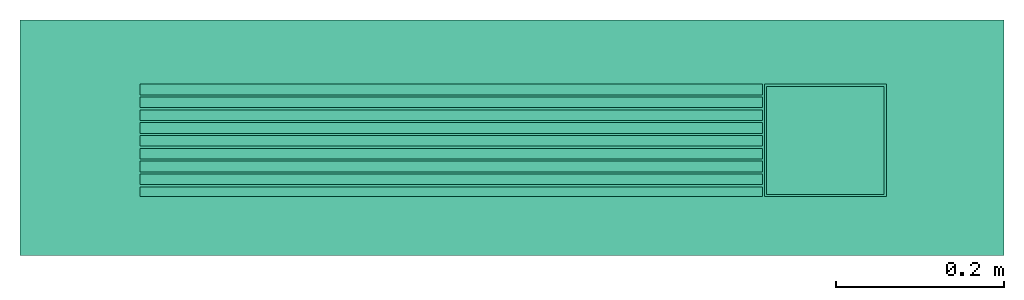
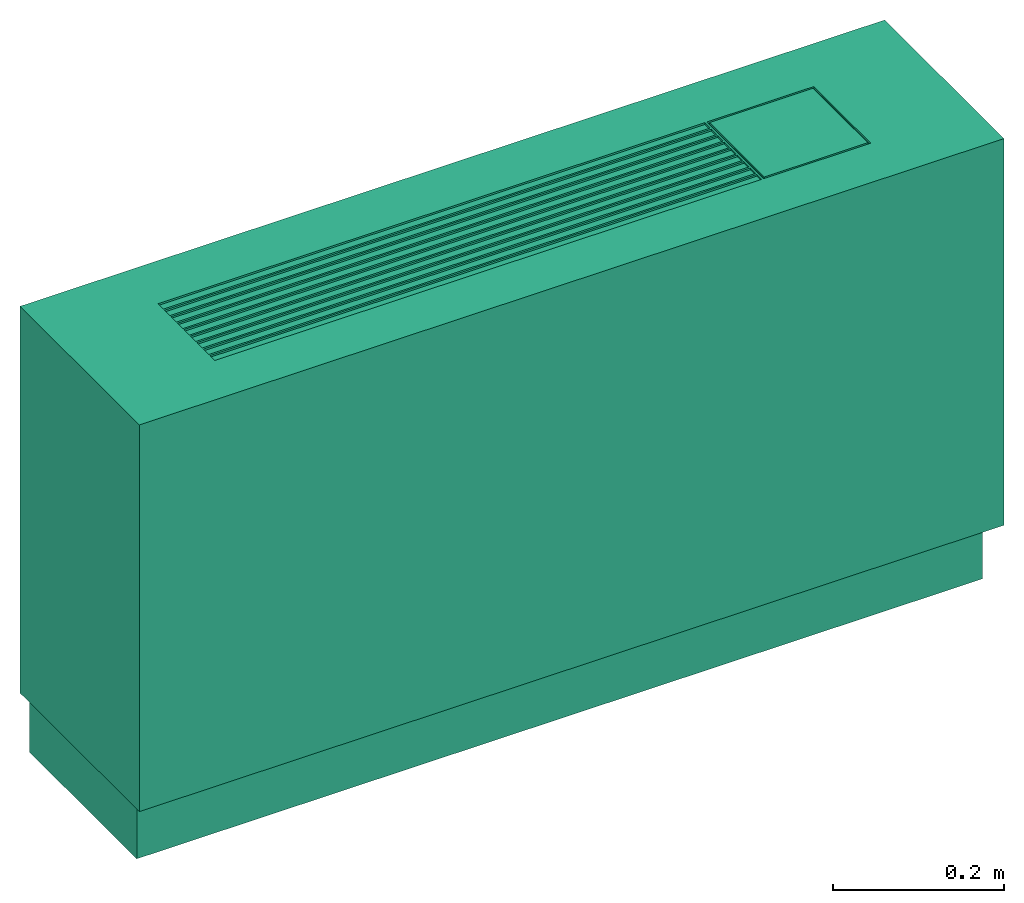
# One storey: 1 energy conversion device.
"""IFC2X3 building model written with IfcOpenShell, lengths in metres."""

from ifc_helpers import new_model, entity, si_unit, converted_unit, origin, origin_with_axes, place, context, subcontext, project, spatial, faceted_brep, type_object, element, save


model = new_model("IFC2X3")

# Units and contexts
model_context = context("Model", 3, precision=1e-05, world=origin())
body_context = subcontext(model_context, "Body", "Model", "MODEL_VIEW")
ifc_project = project(units=[si_unit("LENGTHUNIT", "METRE"), si_unit("AREAUNIT", "SQUARE_METRE"), si_unit("VOLUMEUNIT", "CUBIC_METRE"), converted_unit("PLANEANGLEUNIT", "DEGREE", entity("IfcPlaneAngleMeasure", 0.0174532925199433), si_unit("PLANEANGLEUNIT", "RADIAN"), dimensions=[0, 0, 0, 0, 0, 0, 0]), si_unit("SOLIDANGLEUNIT", "STERADIAN"), si_unit("MASSUNIT", "GRAM"), si_unit("TIMEUNIT", "SECOND"), si_unit("THERMODYNAMICTEMPERATUREUNIT", "DEGREE_CELSIUS"), si_unit("LUMINOUSINTENSITYUNIT", "LUMEN")], contexts=[model_context])

# Site, building, storey
site_placement = place(None, origin_with_axes())
site = spatial("IfcSite", under=ifc_project, at=site_placement, CompositionType="ELEMENT")
building_placement = place(site_placement, origin_with_axes())
building = spatial("IfcBuilding", under=site, at=building_placement, CompositionType="ELEMENT")
storey_placement = place(building_placement, origin_with_axes())
storey = spatial("IfcBuildingStorey", under=building, at=storey_placement, CompositionType="ELEMENT", Elevation=0.0)

# Energy conversion device
heat_exchanger_type = type_object("IfcHeatExchangerType", Name="Console Water Source Heat Pump", PredefinedType="NOTDEFINED")
energy_conversion_device_placement = place(storey_placement, origin_with_axes())
element("IfcEnergyConversionDevice", 1, at=energy_conversion_device_placement, inside=storey, type_object=heat_exchanger_type, Name="Console Water Source Heat Pump", context=body_context, shape_type="Brep", body=[
    faceted_brep([(0.5842, -0.1397, 0.0889), (0.5842, -0.1397, 0.64135), (-0.5842, -0.1397, 0.64135), (-0.5842, -0.1397, 0.0889), (0.4445, 0.0635, 0.64135), (0.299720004844666, 0.0635, 0.64135), (0.299720004844666, 0.0635, 0.63880999031067), (0.4445, 0.0635, 0.63880999031067), (0.297179995155334, -0.06985, 0.64135), (0.297179995155334, -0.06985, 0.63880999031067), (-0.44195999031067, -0.06985, 0.63880999031067), (-0.44195999031067, -0.06985, 0.64135), (0.5715, 0.1397, -7.25807367965477e-18), (0.5715, -0.111760002422333, -7.25807367965477e-18), (-0.5715, -0.111760002422333, -7.25807367965477e-18), (-0.5715, 0.1397, -7.25807367965477e-18), (-0.5715, 0.1397, 0.0889), (-0.5842, 0.1397, 0.64135), (0.5842, 0.1397, 0.64135), (0.5715, 0.1397, 0.0889), (-0.5842, 0.1397, 0.0889), (0.5842, 0.1397, 0.0889), (-0.44195999031067, -0.0584199987888335, 0.64135), (-0.44195999031067, -0.0558800012111665, 0.64135), (-0.44195999031067, -0.0431800012111665, 0.64135), (-0.44195999031067, -0.0406400006055832, 0.64135), (-0.44195999031067, -0.0279400006055832, 0.64135), (-0.44195999031067, -0.0254, 0.64135), (0.299720004844666, -0.06985, 0.64135), (0.4445, -0.06985, 0.64135), (-0.44195999031067, -0.0127, 0.64135), (-0.44195999031067, -0.0101600001513958, 0.64135), (-0.44195999031067, 0.00254000003784895, 0.64135), (-0.44195999031067, 0.00508000007569789, 0.64135), (-0.44195999031067, 0.0177799996972084, 0.64135), (-0.44195999031067, 0.0330199987888335, 0.64135), (-0.44195999031067, 0.0203200003027916, 0.64135), (-0.44195999031067, 0.0355599993944168, 0.64135), (-0.44195999031067, 0.0482599993944168, 0.64135), (-0.44195999031067, 0.0508, 0.64135), (-0.44195999031067, 0.0635, 0.64135), (0.297179995155334, 0.0635, 0.64135), (-0.5715, -0.111760002422333, 0.0889), (0.5715, -0.111760002422333, 0.0889), (-0.44195999031067, 0.0635, 0.63880999031067), (0.297179995155334, 0.0635, 0.63880999031067), (0.4445, -0.06985, 0.63880999031067), (0.299720004844666, -0.06985, 0.63880999031067), (-0.44195999031067, 0.0203200003027916, 0.63880999031067), (-0.44195999031067, 0.0330199987888335, 0.63880999031067), (-0.44195999031067, 0.0355599993944168, 0.63880999031067), (-0.44195999031067, 0.0482599993944168, 0.63880999031067), (-0.44195999031067, -0.0584199987888335, 0.63880999031067), (-0.44195999031067, 0.0508, 0.63880999031067), (-0.44195999031067, -0.0558800012111665, 0.63880999031067), (-0.44195999031067, -0.0431800012111665, 0.63880999031067), (-0.44195999031067, -0.0406400006055832, 0.63880999031067), (-0.44195999031067, -0.0279400006055832, 0.63880999031067), (-0.44195999031067, -0.0254, 0.63880999031067), (-0.44195999031067, -0.0127, 0.63880999031067), (-0.44195999031067, -0.0101600001513958, 0.63880999031067), (-0.44195999031067, 0.00254000003784895, 0.63880999031067), (-0.44195999031067, 0.00508000007569789, 0.63880999031067), (-0.44195999031067, 0.0177799996972084, 0.63880999031067), (0.4445, 0.0635, 0.636269980621337), (-0.44195999031067, 0.0635, 0.636269980621337), (-0.44195999031067, -0.06985, 0.636269980621337), (0.4445, -0.06985, 0.636269980621337)], [[[0, 1, 2]], [[2, 3, 0]], [[4, 5, 6]], [[6, 7, 4]], [[8, 9, 10]], [[10, 11, 8]], [[12, 13, 14]], [[14, 15, 12]], [[16, 17, 18]], [[18, 19, 16]], [[20, 17, 16]], [[16, 19, 12]], [[12, 15, 16]], [[19, 18, 21]], [[11, 22, 2]], [[23, 2, 22]], [[11, 2, 1]], [[1, 8, 11]], [[2, 23, 24]], [[2, 25, 26]], [[25, 2, 24]], [[26, 27, 2]], [[28, 8, 1]], [[29, 28, 1]], [[2, 27, 30]], [[31, 2, 30]], [[4, 29, 1]], [[31, 32, 2]], [[17, 32, 33]], [[17, 33, 34]], [[35, 17, 36]], [[34, 36, 17]], [[17, 35, 37]], [[37, 38, 17]], [[17, 2, 32]], [[17, 38, 39]], [[17, 39, 40]], [[18, 41, 5]], [[1, 18, 4]], [[5, 4, 18]], [[41, 18, 17]], [[17, 40, 41]], [[42, 3, 20]], [[20, 16, 42]], [[19, 21, 0]], [[0, 43, 19]], [[3, 42, 43]], [[43, 0, 3]], [[43, 42, 14]], [[14, 13, 43]], [[1, 0, 21]], [[21, 18, 1]], [[2, 17, 20]], [[20, 3, 2]], [[14, 42, 16]], [[16, 15, 14]], [[19, 43, 13]], [[13, 12, 19]], [[41, 40, 44]], [[44, 45, 41]], [[4, 7, 46]], [[46, 29, 4]], [[29, 46, 47]], [[47, 28, 29]], [[48, 49, 35]], [[35, 36, 48]], [[50, 51, 38]], [[38, 37, 50]], [[10, 52, 22]], [[22, 11, 10]], [[53, 44, 40]], [[40, 39, 53]], [[54, 55, 24]], [[24, 23, 54]], [[56, 57, 26]], [[26, 25, 56]], [[58, 59, 30]], [[30, 27, 58]], [[60, 61, 32]], [[32, 31, 60]], [[62, 63, 34]], [[34, 33, 62]], [[6, 64, 7]], [[41, 45, 6]], [[6, 5, 41]], [[6, 45, 64]], [[44, 65, 45]], [[64, 45, 65]], [[53, 65, 44]], [[65, 53, 51]], [[51, 50, 65]], [[51, 53, 39]], [[50, 37, 35]], [[35, 49, 50]], [[65, 50, 49]], [[48, 36, 34]], [[34, 63, 48]], [[65, 48, 63]], [[65, 63, 62]], [[48, 65, 49]], [[62, 61, 65]], [[38, 51, 39]], [[32, 61, 62]], [[62, 33, 32]], [[65, 61, 60]], [[60, 66, 65]], [[59, 60, 31]], [[31, 30, 59]], [[66, 60, 59]], [[58, 27, 26]], [[26, 57, 58]], [[66, 58, 57]], [[58, 66, 59]], [[55, 66, 56]], [[57, 56, 66]], [[66, 55, 54]], [[54, 52, 66]], [[10, 66, 52]], [[56, 25, 24]], [[24, 55, 56]], [[52, 23, 22]], [[52, 54, 23]], [[46, 7, 64]], [[64, 67, 46]], [[67, 64, 65]], [[65, 66, 67]], [[9, 67, 66]], [[66, 10, 9]], [[47, 9, 8]], [[47, 46, 67]], [[8, 28, 47]], [[9, 47, 67]]]),
    faceted_brep([(0.297179995155334, -0.0584199987888335, 0.63880999031067), (-0.44195999031067, -0.0584199987888335, 0.63880999031067), (-0.44195999031067, -0.06985, 0.63880999031067), (0.297179995155334, -0.06985, 0.63880999031067), (0.30225999031067, 0.0609600024223327, 0.63880999031067), (0.44195999031067, 0.0609600024223327, 0.63880999031067), (0.4445, 0.0635, 0.63880999031067), (0.299720004844666, 0.0635, 0.63880999031067), (0.30225999031067, -0.0673100024223327, 0.63880999031067), (0.299720004844666, -0.06985, 0.63880999031067), (0.44195999031067, -0.0673100024223327, 0.63880999031067), (0.4445, -0.06985, 0.63880999031067), (0.297179995155334, 0.0635, 0.63880999031067), (-0.44195999031067, 0.0635, 0.63880999031067), (-0.44195999031067, 0.0508, 0.63880999031067), (0.297179995155334, 0.0508, 0.63880999031067), (0.44195999031067, -0.0673100024223327, 0.64135), (0.30225999031067, -0.0673100024223327, 0.64135), (0.44195999031067, 0.0609600024223327, 0.64135), (0.30225999031067, 0.0609600024223327, 0.64135), (0.297179995155334, 0.0203200003027916, 0.63880999031067), (-0.44195999031067, 0.0203200003027916, 0.63880999031067), (-0.44195999031067, 0.0203200003027916, 0.64135), (0.297179995155334, 0.0203200003027916, 0.64135), (0.297179995155334, 0.0330199987888335, 0.63880999031067), (0.297179995155334, 0.0330199987888335, 0.64135), (-0.44195999031067, 0.0330199987888335, 0.64135), (-0.44195999031067, 0.0330199987888335, 0.63880999031067), (0.297179995155334, 0.0482599993944168, 0.63880999031067), (0.297179995155334, 0.0482599993944168, 0.64135), (-0.44195999031067, 0.0482599993944168, 0.64135), (-0.44195999031067, 0.0482599993944168, 0.63880999031067), (0.297179995155334, 0.0355599993944168, 0.63880999031067), (0.297179995155334, 0.0355599993944168, 0.64135), (0.297179995155334, -0.0584199987888335, 0.64135), (-0.44195999031067, -0.0584199987888335, 0.64135), (0.297179995155334, -0.06985, 0.64135), (0.299720004844666, -0.06985, 0.64135), (0.299720004844666, 0.0635, 0.64135), (0.297179995155334, 0.0635, 0.64135), (0.297179995155334, 0.0508, 0.64135), (-0.44195999031067, 0.0508, 0.64135), (0.297179995155334, -0.0431800012111665, 0.63880999031067), (0.297179995155334, -0.0431800012111665, 0.64135), (-0.44195999031067, -0.0431800012111665, 0.64135), (-0.44195999031067, -0.0431800012111665, 0.63880999031067), (0.297179995155334, -0.0558800012111665, 0.63880999031067), (0.297179995155334, -0.0558800012111665, 0.64135), (0.297179995155334, -0.0279400006055832, 0.63880999031067), (0.297179995155334, -0.0279400006055832, 0.64135), (-0.44195999031067, -0.0279400006055832, 0.64135), (-0.44195999031067, -0.0279400006055832, 0.63880999031067), (0.297179995155334, -0.0406400006055832, 0.63880999031067), (0.297179995155334, -0.0406400006055832, 0.64135), (0.297179995155334, -0.0127, 0.63880999031067), (0.297179995155334, -0.0127, 0.64135), (-0.44195999031067, -0.0127, 0.64135), (-0.44195999031067, -0.0127, 0.63880999031067), (0.297179995155334, -0.0254, 0.63880999031067), (0.297179995155334, -0.0254, 0.64135), (0.297179995155334, 0.00254000003784895, 0.63880999031067), (0.297179995155334, 0.00254000003784895, 0.64135), (-0.44195999031067, 0.00254000003784895, 0.64135), (-0.44195999031067, 0.00254000003784895, 0.63880999031067), (0.297179995155334, -0.0101600001513958, 0.63880999031067), (0.297179995155334, -0.0101600001513958, 0.64135), (0.297179995155334, 0.0177799996972084, 0.63880999031067), (0.297179995155334, 0.0177799996972084, 0.64135), (-0.44195999031067, 0.0177799996972084, 0.64135), (-0.44195999031067, 0.0177799996972084, 0.63880999031067), (0.297179995155334, 0.00508000007569789, 0.63880999031067), (0.297179995155334, 0.00508000007569789, 0.64135), (-0.44195999031067, 0.0355599993944168, 0.63880999031067), (-0.44195999031067, 0.0355599993944168, 0.64135), (-0.44195999031067, -0.0558800012111665, 0.63880999031067), (-0.44195999031067, -0.0558800012111665, 0.64135), (-0.44195999031067, -0.0406400006055832, 0.63880999031067), (-0.44195999031067, -0.0406400006055832, 0.64135), (-0.44195999031067, -0.0254, 0.63880999031067), (-0.44195999031067, -0.0254, 0.64135), (-0.44195999031067, -0.0101600001513958, 0.63880999031067), (-0.44195999031067, -0.0101600001513958, 0.64135), (-0.44195999031067, 0.00508000007569789, 0.63880999031067), (-0.44195999031067, 0.00508000007569789, 0.64135), (0.4445, 0.0635, 0.636269980621337), (-0.44195999031067, 0.0635, 0.636269980621337), (-0.44195999031067, -0.06985, 0.636269980621337), (0.4445, -0.06985, 0.636269980621337)], [[[0, 1, 2]], [[2, 3, 0]], [[4, 5, 6]], [[6, 7, 4]], [[8, 4, 7]], [[7, 9, 8]], [[5, 10, 11]], [[11, 6, 5]], [[10, 8, 9]], [[9, 11, 10]], [[12, 13, 14]], [[14, 15, 12]], [[10, 16, 17]], [[17, 8, 10]], [[18, 16, 10]], [[10, 5, 18]], [[5, 4, 19]], [[19, 18, 5]], [[17, 19, 4]], [[4, 8, 17]], [[16, 18, 19]], [[19, 17, 16]], [[20, 21, 22]], [[22, 23, 20]], [[24, 25, 26]], [[26, 27, 24]], [[28, 29, 30]], [[30, 31, 28]], [[29, 28, 32]], [[32, 33, 29]], [[0, 34, 35]], [[35, 1, 0]], [[34, 0, 3]], [[3, 36, 34]], [[37, 9, 7]], [[7, 38, 37]], [[39, 12, 15]], [[15, 40, 39]], [[15, 14, 41]], [[41, 40, 15]], [[42, 43, 44]], [[44, 45, 42]], [[43, 42, 46]], [[46, 47, 43]], [[48, 49, 50]], [[50, 51, 48]], [[49, 48, 52]], [[52, 53, 49]], [[54, 55, 56]], [[56, 57, 54]], [[55, 54, 58]], [[58, 59, 55]], [[60, 61, 62]], [[62, 63, 60]], [[61, 60, 64]], [[64, 65, 61]], [[66, 67, 68]], [[68, 69, 66]], [[67, 66, 70]], [[70, 71, 67]], [[32, 72, 73]], [[73, 33, 32]], [[46, 74, 75]], [[75, 47, 46]], [[52, 76, 77]], [[77, 53, 52]], [[58, 78, 79]], [[79, 59, 58]], [[64, 80, 81]], [[81, 65, 64]], [[70, 82, 83]], [[83, 71, 70]], [[25, 24, 20]], [[20, 23, 25]], [[24, 27, 21]], [[21, 20, 24]], [[66, 69, 82]], [[82, 70, 66]], [[60, 63, 80]], [[80, 64, 60]], [[54, 57, 78]], [[78, 58, 54]], [[48, 51, 76]], [[76, 52, 48]], [[42, 45, 74]], [[74, 46, 42]], [[28, 31, 72]], [[72, 32, 28]], [[7, 6, 84]], [[39, 38, 7]], [[7, 12, 39]], [[7, 84, 12]], [[13, 12, 85]], [[84, 85, 12]], [[14, 13, 85]], [[85, 31, 14]], [[31, 85, 72]], [[31, 41, 14]], [[72, 27, 26]], [[26, 73, 72]], [[85, 27, 72]], [[21, 69, 68]], [[68, 22, 21]], [[85, 69, 21]], [[85, 82, 69]], [[21, 27, 85]], [[82, 85, 63]], [[30, 41, 31]], [[62, 83, 82]], [[82, 63, 62]], [[85, 86, 80]], [[80, 63, 85]], [[57, 56, 81]], [[81, 80, 57]], [[86, 57, 80]], [[78, 51, 50]], [[50, 79, 78]], [[86, 51, 78]], [[78, 57, 86]], [[45, 76, 86]], [[51, 86, 76]], [[86, 74, 45]], [[74, 86, 1]], [[2, 1, 86]], [[76, 45, 44]], [[44, 77, 76]], [[1, 35, 75]], [[1, 75, 74]], [[11, 87, 84]], [[84, 6, 11]], [[87, 86, 85]], [[85, 84, 87]], [[34, 47, 75]], [[75, 35, 34]], [[43, 53, 77]], [[77, 44, 43]], [[49, 59, 79]], [[79, 50, 49]], [[55, 65, 81]], [[81, 56, 55]], [[34, 37, 47]], [[43, 47, 37]], [[34, 36, 37]], [[37, 53, 43]], [[53, 37, 49]], [[59, 49, 37]], [[65, 55, 37]], [[59, 37, 55]], [[61, 65, 37]], [[61, 71, 83]], [[83, 62, 61]], [[22, 68, 67]], [[67, 23, 22]], [[73, 26, 25]], [[25, 33, 73]], [[30, 29, 40]], [[40, 41, 30]], [[67, 71, 38]], [[38, 23, 67]], [[23, 38, 25]], [[38, 29, 33]], [[38, 39, 40]], [[29, 38, 40]], [[25, 38, 33]], [[61, 38, 71]], [[37, 38, 61]], [[3, 2, 86]], [[86, 87, 3]], [[9, 36, 3]], [[9, 87, 11]], [[36, 9, 37]], [[3, 87, 9]]]),
])

save(model, "model.ifc")
